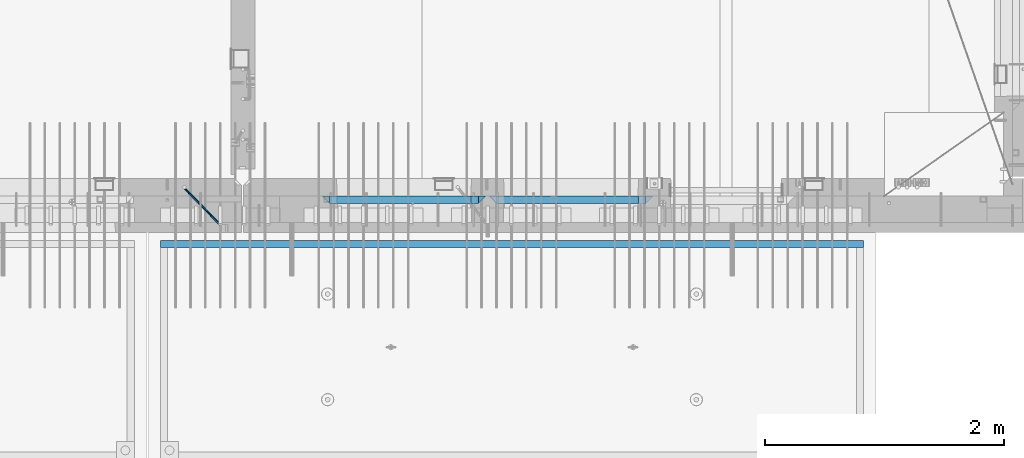
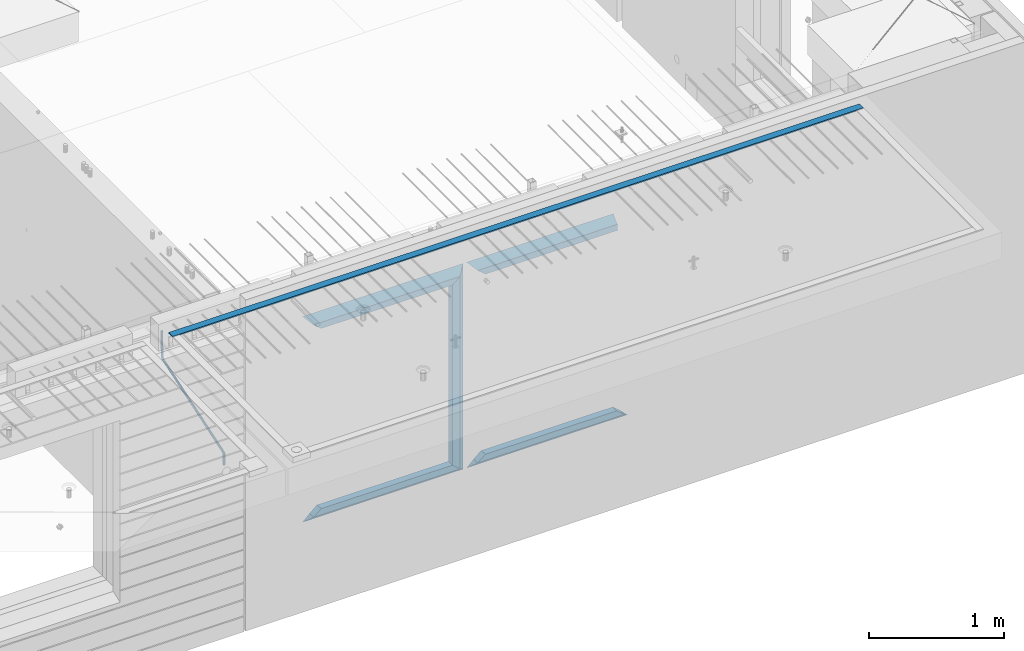
# One storey, part 98 of 349: 12 beams, 3 elements without a shape of their own.
"""IFC2X3 building model written with IfcOpenShell, lengths in millimetres."""

from ifc_helpers import new_model, si_unit, frame, origin_with_axes, place, context, subcontext, project, spatial, faceted_brep, material, type_object, element, aggregate, save


model = new_model("IFC2X3")

# Units and contexts
model_context = context("Model", 3, precision=1e-05, world=origin_with_axes())
body_context = subcontext(model_context, "Body", "Model", "MODEL_VIEW")
ifc_project = project(units=[si_unit("LENGTHUNIT", "METRE", prefix="MILLI"), si_unit("AREAUNIT", "SQUARE_METRE"), si_unit("VOLUMEUNIT", "CUBIC_METRE"), si_unit("MASSUNIT", "GRAM", prefix="KILO"), si_unit("TIMEUNIT", "SECOND"), si_unit("PLANEANGLEUNIT", "RADIAN"), si_unit("SOLIDANGLEUNIT", "STERADIAN"), si_unit("THERMODYNAMICTEMPERATUREUNIT", "DEGREE_CELSIUS"), si_unit("LUMINOUSINTENSITYUNIT", "LUMEN")], contexts=[model_context])

# Site, building, storey
site_placement = place(None, origin_with_axes())
site = spatial("IfcSite", under=ifc_project, at=site_placement, CompositionType="ELEMENT")
building_placement = place(site_placement, origin_with_axes())
building = spatial("IfcBuilding", under=site, at=building_placement, CompositionType="ELEMENT")
storey_placement = place(building_placement, origin_with_axes())
storey = spatial("IfcBuildingStorey", under=building, at=storey_placement, Name="4", CompositionType="ELEMENT", Elevation=0.0)

# Assembly, beam
assembly_1_placement = place(storey_placement, origin_with_axes())
assembly_1 = element("IfcElementAssembly", 1, at=assembly_1_placement, inside=storey, AssemblyPlace="NOTDEFINED", PredefinedType="REINFORCEMENT_UNIT")
ifc_material_1 = material()
beam_type_1 = type_object("IfcBeamType", Name="D20", PredefinedType="NOTDEFINED")
beam_1_placement = place(assembly_1_placement, frame((28120.0219996506, 7924.99999995055, 93407.5), z_axis=(-0.000415599999849952, -0.999999913638316, 0.0), x_axis=(-0.00018169900008877, 0.0, -0.999999983492737)))
beam_1 = element("IfcBeam", 2, at=beam_1_placement, type_object=beam_type_1, material=ifc_material_1, Name="JM20", ObjectType="D20", context=body_context, shape_type="Brep", body=[
    faceted_brep([(-0.00060564729210455, -9.99999998165731, 0.0), (-0.000428079845733009, -7.07106779890455, -7.07106781186667), (119.575515501536, -7.07830994756296, -7.07106481604933), (119.575337932896, -10.0072421307195, -3.43332612828817e-06), (0.0, 0.0, -10.0), (119.575943836026, -0.00724214867295814, -9.99999700418266), (0.00042843479604926, 7.07106779888636, -7.07106781186303), (119.57637202373, 7.06382565022977, -7.07106481604933), (0.00060564729210455, 9.99999998166459, 3.63797880709171e-12), (119.576549238118, 9.99275783300072, 2.99581552098971e-06), (0.000428079845733009, 7.07106779890819, 7.07106781186667), (119.576371669405, 7.06382565024978, 7.07107080768037), (0.0, 0.0, 10.0), (119.57594333493, -0.00724214864203532, 10.0000029958155), (-0.000428434810601175, -7.07106779888272, 7.07106781186667), (119.575515147211, -7.07830994754295, 7.07107080768037), (123.007838984922, -7.07805953274146, -6.96781646693489), (122.583416564885, -10.0070226667376, 0.0904895847234002), (123.182432386879, -0.00697902713727672, -9.89150957511447), (123.004922326727, 7.0640757898218, -6.96792996825661), (122.579291790258, 9.99297690664025, 0.09032907062101), (122.154869373029, 7.06401377197108, 7.14863512328429), (121.980275971029, -0.00706673364766175, 10.0723282314621), (122.157786031181, -7.0781215506031, 7.1487486246051), (232.991069545737, -7.0553235628031, -0.344989315878593), (232.56664713427, -9.98428669916029, 6.71331673826626), (233.165662947809, 0.0157569427356066, -3.26868242414184), (232.988152887861, 7.08681175970924, -0.345102817348561), (232.562522351524, 10.0157128766077, 6.71315622151724), (232.138099934426, 7.08674974201131, 13.7714622742333), (231.963506532353, 0.0156692364653281, 16.6951553824965), (232.141016592301, -7.05538558050466, 13.7715757757042), (248.076986635424, -5.5847993905918, 1.85861828010275), (247.029610002806, -8.57448599522468, 8.8259290931519), (244.875536996158, -5.81406760439131, 15.6317136598209), (242.87659436863, 1.07944012639928, 18.2892356835691), (242.20373560088, 8.06791386077748, 15.2417548051744), (243.251112233527, 11.0576004654249, 8.27444399212709), (245.405185240103, 8.29718207458427, 1.4686594254481), (247.40412786763, 1.40367434377549, -1.1888625983047), (260.566830172145, 5.47100196453175, 3.19131575132906), (262.023113325369, -1.27539050352425, 6.49949830426976), (256.884070167318, 11.8442033958454, 5.28851055269934), (253.132144174728, 14.110878827727, 11.5625744366826), (251.508879555811, 10.9432405336265, 18.3382458712176), (252.965162709021, 4.19684806558143, 21.6464284241465), (256.647922713819, -2.17635336575768, 19.5492336227662), (260.399848700399, -4.44302879667157, 13.2751697364092), (1011.72756124764, 322.959435794994, 337.688425673249), (1010.10429662876, 319.79179750097, 344.464097107826), (1010.27127809466, 329.705828263024, 334.380243120345), (1006.58851809015, 336.079029694381, 336.477437921801), (1002.83659209782, 338.345705126318, 342.751501805859), (1001.21332747894, 335.178066832297, 349.527173240437), (1002.66961063194, 328.431674364263, 352.835355793341), (1006.35237063644, 322.058472932906, 350.738160991886), (1012.15285167976, 323.143366902459, 337.876301685487), (1011.27592458235, 320.298507294498, 344.981674676291), (1011.36533099508, 330.178988123705, 334.863551186057), (1009.37468146477, 337.283999466545, 337.708251560521), (1007.34699858574, 340.296381647149, 344.744015910405), (1006.47007148832, 337.45152203918, 351.849388901209), (1007.25759217299, 330.415900817941, 354.862139400639), (1009.24824170329, 323.310889475106, 352.017439026175), (1012.6528516715, 323.14345775195, 337.876301647731), (1012.65336908352, 320.298757574768, 344.981674572278), (1012.65157305435, 330.179221832586, 334.863551088932), (1012.65028222866, 337.284594639881, 337.708251313175), (1012.64973534261, 340.297345149043, 344.744015509988), (1012.65025275464, 337.452644971851, 351.849388434534), (1012.65153137178, 330.416880891225, 354.862138993334), (1012.65282219746, 323.311508083931, 352.017438769089), (1117.44132683994, 323.162497711652, 337.876293734989), (1117.44184425197, 320.31779753447, 344.981666659536), (1117.44004822278, 330.198261792288, 334.863543176189), (1117.43875739709, 337.303634599582, 337.708243400433), (1117.43821051104, 340.316385108745, 344.744007597245), (1117.43872792307, 337.471684931556, 351.849380521792), (1117.44000654022, 330.435920850927, 354.862131080592), (1117.44129736591, 323.330548043632, 352.017430856347)], [[[0, 1, 2, 3]], [[1, 4, 5, 2]], [[4, 6, 7, 5]], [[6, 8, 9, 7]], [[8, 10, 11, 9]], [[10, 12, 13, 11]], [[12, 14, 15, 13]], [[14, 0, 3, 15]], [[14, 12, 10, 8, 6, 4, 1, 0]], [[3, 2, 16, 17]], [[2, 5, 18, 16]], [[5, 7, 19, 18]], [[7, 9, 20, 19]], [[9, 11, 21, 20]], [[11, 13, 22, 21]], [[13, 15, 23, 22]], [[15, 3, 17, 23]], [[17, 16, 24, 25]], [[16, 18, 26, 24]], [[18, 19, 27, 26]], [[19, 20, 28, 27]], [[20, 21, 29, 28]], [[21, 22, 30, 29]], [[22, 23, 31, 30]], [[23, 17, 25, 31]], [[25, 24, 32, 33]], [[31, 25, 33, 34]], [[30, 31, 34, 35]], [[29, 30, 35, 36]], [[28, 29, 36, 37]], [[27, 28, 37, 38]], [[26, 27, 38, 39]], [[24, 26, 39, 32]], [[39, 40, 41, 32]], [[38, 42, 40, 39]], [[37, 43, 42, 38]], [[36, 44, 43, 37]], [[35, 45, 44, 36]], [[34, 46, 45, 35]], [[33, 47, 46, 34]], [[32, 41, 47, 33]], [[47, 41, 48, 49]], [[41, 40, 50, 48]], [[40, 42, 51, 50]], [[42, 43, 52, 51]], [[43, 44, 53, 52]], [[44, 45, 54, 53]], [[45, 46, 55, 54]], [[46, 47, 49, 55]], [[49, 48, 56, 57]], [[48, 50, 58, 56]], [[50, 51, 59, 58]], [[51, 52, 60, 59]], [[52, 53, 61, 60]], [[53, 54, 62, 61]], [[54, 55, 63, 62]], [[55, 49, 57, 63]], [[57, 56, 64, 65]], [[56, 58, 66, 64]], [[58, 59, 67, 66]], [[59, 60, 68, 67]], [[60, 61, 69, 68]], [[61, 62, 70, 69]], [[62, 63, 71, 70]], [[63, 57, 65, 71]], [[65, 64, 72, 73]], [[64, 66, 74, 72]], [[66, 67, 75, 74]], [[67, 68, 76, 75]], [[68, 69, 77, 76]], [[69, 70, 78, 77]], [[70, 71, 79, 78]], [[71, 65, 73, 79]], [[74, 75, 76, 77, 78, 79, 73, 72]]]),
])
aggregate(assembly_1, [beam_1])

assembly_2_placement = place(storey_placement, origin_with_axes())
assembly_2 = element("IfcElementAssembly", 3, at=assembly_2_placement, inside=storey, AssemblyPlace="NOTDEFINED", PredefinedType="REINFORCEMENT_UNIT")
ifc_material_2 = material(Name="CONCRETE/Concrete_Undefined")
beam_type_2 = type_object("IfcBeamType", PredefinedType="NOTDEFINED")
beam_2_placement = place(assembly_2_placement, frame((33810.0034098489, 7449.93184428067, 93725.278844281), z_axis=(6.5298999993069e-05, -1.00000033840378e-09, 0.99999999786802), x_axis=(-0.999999997792817, 1.22639999974798e-05, 6.52989999859729e-05)))
beam_2 = element("IfcBeam", 4, at=beam_2_placement, type_object=beam_type_2, material=ifc_material_2, context=body_context, shape_type="Brep", body=[
    faceted_brep([(2.5465851649642e-11, 29.9999999999982, -4.99999999998545), (-2.91038304567337e-11, 29.9999999999982, 5.0), (5890.06001043805, 29.9999999999991, 5.00000000001455), (5890.06001043806, 30.0, -4.99999999998545), (-2.5465851649642e-11, -30.0000000000018, 5.0), (5890.06001043806, -30.0, 5.00000000001455), (2.72848410531878e-11, -30.0000000000018, -4.99999999998545), (5890.06001043806, -30.0, -5.0)], [[[0, 1, 2, 3]], [[1, 4, 5, 2]], [[4, 6, 7, 5]], [[6, 0, 3, 7]], [[5, 7, 3, 2]], [[6, 4, 1, 0]]]),
])
aggregate(assembly_2, [beam_2])

# Assembly, beams
assembly_3_placement = place(storey_placement, origin_with_axes())
assembly_3 = element("IfcElementAssembly", 5, at=assembly_3_placement, inside=storey, AssemblyPlace="NOTDEFINED", PredefinedType="REINFORCEMENT_UNIT")
ifc_material_3 = material(Name="CONCRETE/C35/45")
beam_type_3 = type_object("IfcBeamType", PredefinedType="NOTDEFINED")
beam_3_placement = place(assembly_3_placement, frame((30674.9996552717, 7820.0, 93145.0), z_axis=(0.0, 0.0, -1.0), x_axis=(1.0, 0.0, 0.0)))
beam_3 = element("IfcBeam", 6, at=beam_3_placement, type_object=beam_type_3, material=ifc_material_3, Name="SK", context=body_context, shape_type="Brep", body=[
    faceted_brep([(1249.99847412109, -30.0, 30.0), (1249.99847412109, -29.999999998452, -30.0), (1249.99847412109, 30.0, 30.0), (60.0000000000073, -30.0, 30.0), (0.0, -30.0, -30.0), (60.0000000000073, 30.0, 30.0)], [[[0, 1, 2]], [[1, 0, 3, 4]], [[2, 1, 4, 5]], [[0, 2, 5, 3]], [[5, 4, 3]]]),
])
beam_4_placement = place(assembly_3_placement, frame((30734.9996552717, 7820.0, 93085.0), z_axis=(0.0, 0.0, -1.0), x_axis=(1.0, 0.0, 0.0)))
beam_4 = element("IfcBeam", 7, at=beam_4_placement, type_object=beam_type_3, material=ifc_material_3, Name="SK", context=body_context, shape_type="Brep", body=[
    faceted_brep([(1189.99847412109, -30.0, 30.0), (1189.99847412109, -30.0, -30.0), (1189.99847412109, 30.0, -30.0), (1189.99847412109, 30.0, 30.0), (1184.32279844542, 30.0, 30.0), (1185.94442006704, -30.0, 30.0), (1184.32279844542, 29.999999998452, 25.6756756756804), (1185.94442006696, -29.999999998452, 24.0540540541406), (65.6741497967687, 29.999999998452, 25.6756756756804), (64.0525281752307, -29.999999998452, 24.0540540541406), (65.6741497967687, 29.999999998452, 26.2921283848846), (64.0525281752307, -29.999999998452, 24.9021669953072), (0.0, -30.0, -30.0), (0.0, 30.0, -30.0)], [[[0, 1, 2, 3]], [[0, 3, 4, 5]], [[5, 4, 6, 7]], [[7, 6, 8, 9]], [[9, 8, 10, 11]], [[1, 0, 5, 7, 9, 11, 12]], [[2, 1, 12, 13]], [[8, 6, 4, 3, 2, 13, 10]], [[10, 13, 12, 11]]]),
])
ifc_material_4 = material(Name="CONCRETE/C30/37")
beam_5_placement = place(assembly_3_placement, frame((32044.9981293928, 7820.0, 91350.0), z_axis=(0.0, 0.0, 1.0), x_axis=(-1.0, 3.00000001838171e-08, 0.0)))
beam_5 = element("IfcBeam", 8, at=beam_5_placement, type_object=beam_type_3, material=ifc_material_4, Name="SK", context=body_context, shape_type="Brep", body=[
    faceted_brep([(1309.99847412109, 30.0, 30.0), (1309.99847412109, -30.0, 30.0), (1369.99847412109, -30.0, -30.0), (0.0, -30.0, -30.0), (60.0000000000073, 30.0, 30.0), (60.0000000000073, -30.0, 30.0)], [[[0, 1, 2]], [[3, 4, 0, 2]], [[4, 5, 1, 0]], [[5, 3, 2, 1]], [[4, 3, 5]]]),
])
beam_6_placement = place(assembly_3_placement, frame((31984.9981293928, 7820.0, 91410.0), z_axis=(0.0, 0.0, 1.0), x_axis=(-1.0, 3.00000001838171e-08, 0.0)))
beam_6 = element("IfcBeam", 9, at=beam_6_placement, type_object=beam_type_3, material=ifc_material_4, Name="SK", context=body_context, shape_type="Brep", body=[
    faceted_brep([(1185.94594588314, -29.9999988381387, 24.0540541168593), (1184.32432432432, 29.9999988381387, 25.6756756756804), (65.6756756756768, 30.0, 25.6756756756804), (64.0540540540533, -30.0, 24.0540540540533), (1185.94594594586, -29.999999998452, 24.9021669952926), (1184.32432432433, 29.999999998452, 26.2921283848846), (1249.99847412109, -29.999999998452, -30.0), (1249.99847412109, 29.999999998452, -30.0), (0.0, -30.0, -30.0), (0.0, 30.0, -30.0), (65.6756756756768, 30.0, 26.293436281092), (64.0540540540533, -30.0, 24.9034748914419)], [[[0, 1, 2, 3]], [[1, 0, 4, 5]], [[5, 4, 6, 7]], [[8, 9, 7, 6]], [[2, 1, 5, 7, 9, 10]], [[3, 2, 10, 11]], [[6, 4, 0, 3, 11, 8]], [[8, 11, 10, 9]]]),
])
beam_7_placement = place(assembly_3_placement, frame((29275.0000367414, 7820.0, 93145.0), z_axis=(0.0, 0.0, -1.0), x_axis=(1.0, 0.0, 0.0)))
beam_7 = element("IfcBeam", 10, at=beam_7_placement, type_object=beam_type_3, material=ifc_material_3, Name="SK", context=body_context, shape_type="Brep", body=[
    faceted_brep([(60.0000000000073, 30.0, 30.0), (0.0, -30.0, -30.0), (60.0000000000073, -30.0, 30.0), (1370.00038146973, -30.0, -30.0), (1310.0003814697, -30.0, 30.0), (1310.0003814697, 30.0, 30.0)], [[[0, 1, 2]], [[2, 1, 3, 4]], [[0, 2, 4, 5]], [[1, 0, 5, 3]], [[3, 5, 4]]]),
])
beam_8_placement = place(assembly_3_placement, frame((29335.0000367414, 7820.0, 93085.0), z_axis=(0.0, 0.0, -1.0), x_axis=(1.0, 0.0, 0.0)))
beam_8 = element("IfcBeam", 11, at=beam_8_placement, type_object=beam_type_3, material=ifc_material_3, Name="SK", context=body_context, shape_type="Brep", body=[
    faceted_brep([(1185.94632735287, -29.9999988381387, 24.0540541168593), (1184.32470579405, 29.9999988381387, 25.6756756756804), (65.6760571454033, 29.9999988381387, 25.6756756756804), (64.0544355865859, -29.9999988381387, 24.0540541168593), (65.6760571454033, 29.9999988381387, 26.2937632551475), (64.0544355865859, -29.9999988381387, 24.9038019193104), (0.0, 30.0, -30.0), (0.0, -30.0, -30.0), (1250.00038146973, -29.9999988381387, -30.0), (1185.94632735287, -29.9999988381387, 24.9034749452549), (1184.32470579405, 29.9999988381387, 26.2934362810629), (1250.00038146973, 29.9999988381387, -30.0)], [[[0, 1, 2, 3]], [[3, 2, 4, 5]], [[5, 4, 6, 7]], [[0, 3, 5, 7, 8, 9]], [[1, 0, 9, 10]], [[6, 4, 2, 1, 10, 11]], [[7, 6, 11, 8]], [[8, 11, 10, 9]]]),
])
beam_9_placement = place(assembly_3_placement, frame((30615.0004182112, 7820.0, 93175.0), z_axis=(-1.0, 3.00000001838171e-08, 0.0), x_axis=(0.0, 0.0, -1.0)))
beam_9 = element("IfcBeam", 12, at=beam_9_placement, type_object=beam_type_3, material=ifc_material_3, Name="SK", context=body_context, shape_type="Brep", body=[
    faceted_brep([(60.0000000000073, 30.0, 30.0), (0.0, -30.0, -30.0), (60.0000000000073, -30.0, 30.0), (1855.0, -30.0, -30.0), (1795.00000000001, -30.0, 30.0), (1795.00000000001, 30.0, 30.0)], [[[0, 1, 2]], [[3, 4, 2, 1]], [[4, 5, 0, 2]], [[5, 3, 1, 0]], [[4, 3, 5]]]),
])
beam_10_placement = place(assembly_3_placement, frame((30645.0004182112, 7820.0, 91350.0), z_axis=(0.0, 0.0, 1.0), x_axis=(-1.0, 3.00000001838171e-08, 0.0)))
beam_10 = element("IfcBeam", 13, at=beam_10_placement, type_object=beam_type_3, material=ifc_material_4, Name="SK", context=body_context, shape_type="Brep", body=[
    faceted_brep([(1370.00038146973, -30.0, -30.0), (1310.0003814697, 30.0, 30.0), (1310.0003814697, -30.0, 30.0), (0.0, -30.0, -30.0), (60.0000000000073, 30.0, 30.0), (60.0000000000073, -30.0, 30.0)], [[[0, 1, 2]], [[3, 4, 1, 0]], [[4, 5, 2, 1]], [[5, 3, 0, 2]], [[4, 3, 5]]]),
])
beam_11_placement = place(assembly_3_placement, frame((30585.0004182112, 7820.0, 91410.0), z_axis=(0.0, 0.0, 1.0), x_axis=(-1.0, 3.00000001838171e-08, 0.0)))
beam_11 = element("IfcBeam", 14, at=beam_11_placement, type_object=beam_type_3, material=ifc_material_4, Name="SK", context=body_context, shape_type="Brep", body=[
    faceted_brep([(1185.94594588314, -29.9999988381387, 24.0540541168593), (1184.32432432432, 29.9999988381387, 25.6756756756804), (65.6756756756768, 30.0, 25.6756756756804), (64.0540540540533, -30.0, 24.0540540540533), (1185.94594588314, -29.9999988381387, 24.9038019193104), (1184.32432432432, 29.9999988381387, 26.2937632551329), (1250.00038146973, -29.9999988381387, -30.0), (1250.00038146973, 29.9999988381387, -30.0), (0.0, -30.0, -30.0), (0.0, 30.0, -30.0), (65.6756756756768, 30.0, 26.293436281092), (64.0540540540533, -30.0, 24.9034748914419)], [[[0, 1, 2, 3]], [[1, 0, 4, 5]], [[4, 6, 7, 5]], [[8, 9, 7, 6]], [[2, 1, 5, 7, 9, 10]], [[3, 2, 10, 11]], [[6, 4, 0, 3, 11, 8]], [[8, 11, 10, 9]]]),
])
beam_type_4 = type_object("IfcBeamType", PredefinedType="NOTDEFINED")
beam_12_placement = place(assembly_3_placement, frame((30550.0004182112, 7820.0, 93115.0), z_axis=(-1.0, 3.00000001838171e-08, 0.0), x_axis=(0.0, 0.0, -1.0)))
beam_12 = element("IfcBeam", 15, at=beam_12_placement, type_object=beam_type_4, material=ifc_material_3, Name="SK", context=body_context, shape_type="Brep", body=[
    faceted_brep([(0.0, -30.0, -35.0), (54.9034748914273, -30.0, 29.0540540540533), (56.2934362811066, 30.0, 30.6756756756768), (0.0, 30.0, -35.0), (1735.0, -30.0, -35.0), (1680.09652510857, -30.0, 29.0540540540533), (1678.70656371891, 30.0, 30.6756756756768), (1735.0, 30.0, -35.0)], [[[0, 1, 2, 3]], [[1, 0, 4, 5]], [[2, 1, 5, 6]], [[3, 2, 6, 7]], [[7, 4, 0, 3]], [[4, 7, 6, 5]]]),
])
aggregate(assembly_3, [beam_3, beam_4, beam_5, beam_6, beam_7, beam_8, beam_9, beam_12, beam_10, beam_11])

save(model, "model.ifc")
